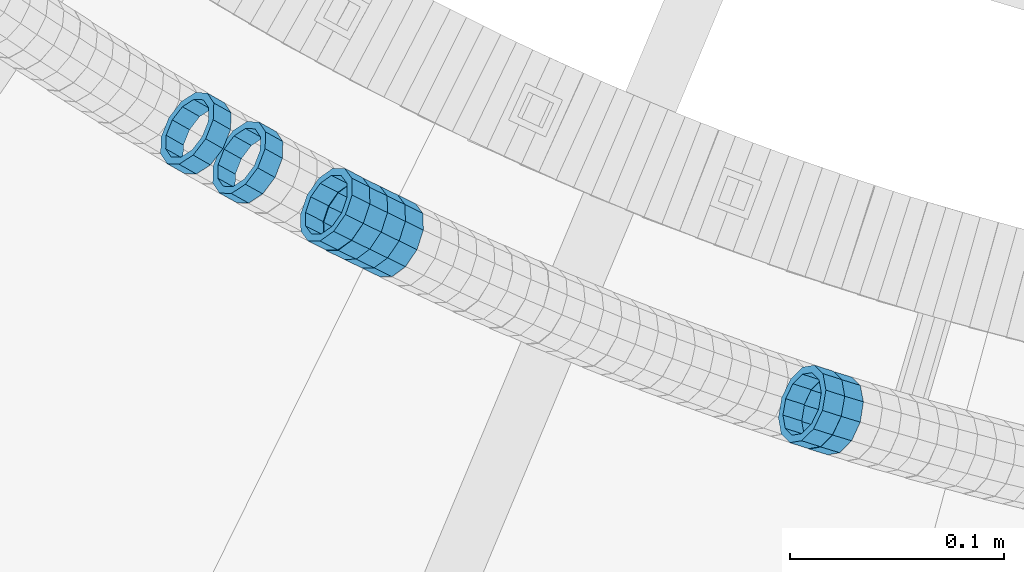
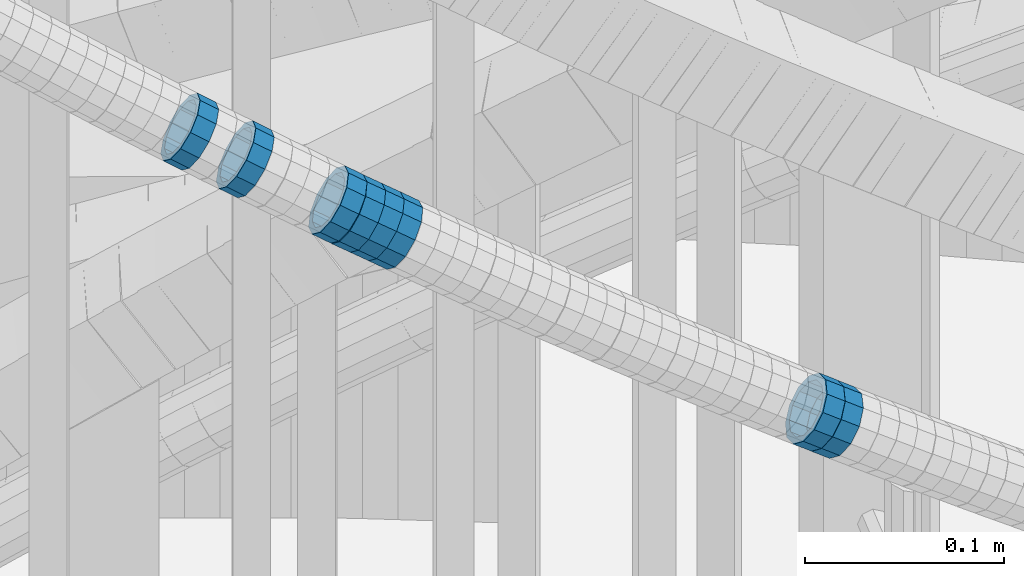
# One storey, part 692 of 975: 8 members.
"""IFC2X3 building model written with IfcOpenShell, lengths in millimetres."""

from ifc_helpers import new_model, si_unit, frame, origin_with_axes, place, context, subcontext, project, spatial, faceted_brep, material, type_object, element, save


model = new_model("IFC2X3")

# Units and contexts
model_context = context("Model", 3, precision=1e-05, world=origin_with_axes())
body_context = subcontext(model_context, "Body", "Model", "MODEL_VIEW")
ifc_project = project(units=[si_unit("LENGTHUNIT", "METRE", prefix="MILLI"), si_unit("AREAUNIT", "SQUARE_METRE"), si_unit("VOLUMEUNIT", "CUBIC_METRE"), si_unit("MASSUNIT", "GRAM", prefix="KILO"), si_unit("TIMEUNIT", "SECOND"), si_unit("PLANEANGLEUNIT", "RADIAN"), si_unit("SOLIDANGLEUNIT", "STERADIAN"), si_unit("THERMODYNAMICTEMPERATUREUNIT", "DEGREE_CELSIUS"), si_unit("LUMINOUSINTENSITYUNIT", "LUMEN")], contexts=[model_context])

# Site, building, storey
site_placement = place(None, origin_with_axes())
site = spatial("IfcSite", under=ifc_project, at=site_placement, CompositionType="ELEMENT")
building_placement = place(site_placement, origin_with_axes())
building = spatial("IfcBuilding", under=site, at=building_placement, Name="Undefined", CompositionType="ELEMENT")
storey_placement = place(building_placement, origin_with_axes())
storey = spatial("IfcBuildingStorey", under=building, at=storey_placement, Name="Undefined", CompositionType="ELEMENT", Elevation=0.0)

# Members
ifc_material = material()
member_type = type_object("IfcMemberType", PredefinedType="NOTDEFINED")
member_1_placement = place(storey_placement, frame((34293.7503061323, 1991.13379938995, 4482.93561378723), z_axis=(-0.290305798469577, -0.95693392842711, -3.87069121643435e-10), x_axis=(-0.811981609245626, 0.246331499074519, 0.529156554160093)))
element("IfcMember", 1, at=member_1_placement, inside=storey, type_object=member_type, material=ifc_material, Name="WALL", context=body_context, shape_type="Brep", body=[
    faceted_brep([(-2.1246523829177e-07, -15.367000000002, 0.0), (-1.83998054126278e-07, -13.3082123799541, 7.68350000000009), (10.9608393839299, -13.3082123799613, 7.68350000000282), (10.9608393839189, -15.3670000000093, 3.63797880709171e-12), (-1.06232619145885e-07, -7.68349999999919, 13.3082123799559), (10.9608393839408, -7.68349999999919, 13.3082123799563), (-3.63797880709171e-12, 3.63797880709171e-12, 15.3670000000002), (10.9608393839517, 3.63797880709171e-12, 15.3669999999993), (1.06225343188271e-07, 7.68350000000646, 13.3082123799559), (10.960839383959, 7.68350000000282, 13.3082123799536), (1.8399441614747e-07, 13.308212379965, 7.68350000000009), (10.9608393839553, 13.3082123799577, 7.68349999999782), (2.12461600312963e-07, 15.3670000000093, 0.0), (10.960839383959, 15.367000000002, -2.27373675443232e-12), (1.8399441614747e-07, 13.308212379965, -7.68350000000009), (10.960839383948, 13.3082123799468, -7.68350000000146), (1.06225343188271e-07, 7.68350000000646, -13.3082123799559), (10.9608393839408, 7.68349999998827, -13.3082123799563), (-3.63797880709171e-12, 3.63797880709171e-12, -15.3670000000002), (10.9608393839299, -1.09139364212751e-11, -15.3669999999993), (-1.06232619145885e-07, -7.68349999999919, -13.3082123799559), (10.9608393839226, -7.68350000001374, -13.3082123799531), (-1.83998054126278e-07, -13.3082123799541, -7.68350000000009), (10.9608393839226, -13.308212379965, -7.68349999999691), (-2.63386027654633e-07, -19.0500000000029, 0.0), (-2.28097633225843e-07, -16.4977839420972, -9.52499999999964), (10.9608393839153, -16.4977839421081, -9.52499999999645), (10.9608393839153, -19.0500000000065, 4.09272615797818e-12), (-1.31691194837913e-07, -9.52500000000146, -16.4977839420935), (10.9608393839189, -9.52500000001237, -16.4977839420908), (-3.63797880709171e-12, 3.63797880709171e-12, -19.0500000000002), (10.9608393839262, -1.45519152283669e-11, -19.0499999999984), (1.31687556859106e-07, 9.52500000000509, -16.4977839420935), (10.9608393839371, 9.5249999999869, -16.4977839420935), (2.28097633225843e-07, 16.4977839421044, -9.52499999999964), (10.9608393839553, 16.4977839420899, -9.52500000000282), (2.63382389675826e-07, 19.0500000000138, 0.0), (10.9608393839626, 19.0499999999993, -3.18323145620525e-12), (2.28097633225843e-07, 16.4977839421044, 9.52499999999964), (10.9608393839626, 16.4977839420972, 9.52499999999645), (1.31687556859106e-07, 9.52500000000509, 16.4977839420935), (10.960839383959, 9.52500000000509, 16.4977839420917), (-3.63797880709171e-12, 3.63797880709171e-12, 19.0500000000002), (10.9608393839517, 7.27595761418343e-12, 19.0499999999997), (-1.31691194837913e-07, -9.52500000000146, 16.4977839420935), (10.9608393839408, -9.52499999999782, 16.4977839420944), (-2.28097633225843e-07, -16.4977839420972, 9.52499999999964), (10.9608393839226, -16.4977839420972, 9.52500000000418)], [[[0, 1, 2, 3]], [[1, 4, 5, 2]], [[4, 6, 7, 5]], [[6, 8, 9, 7]], [[8, 10, 11, 9]], [[10, 12, 13, 11]], [[12, 14, 15, 13]], [[14, 16, 17, 15]], [[16, 18, 19, 17]], [[18, 20, 21, 19]], [[20, 22, 23, 21]], [[22, 0, 3, 23]], [[24, 25, 26, 27]], [[25, 28, 29, 26]], [[28, 30, 31, 29]], [[30, 32, 33, 31]], [[32, 34, 35, 33]], [[34, 36, 37, 35]], [[36, 38, 39, 37]], [[38, 40, 41, 39]], [[40, 42, 43, 41]], [[42, 44, 45, 43]], [[44, 46, 47, 45]], [[46, 24, 27, 47]], [[29, 31, 33, 35, 37, 39, 41, 43, 45, 47, 27, 26], [5, 7, 9, 11, 13, 15, 17, 19, 21, 23, 3, 2]], [[46, 44, 42, 40, 38, 36, 34, 32, 30, 28, 25, 24], [22, 20, 18, 16, 14, 12, 10, 8, 6, 4, 1, 0]]]),
])
member_2_placement = place(storey_placement, frame((34284.961814162, 1993.94119133167, 4488.68931985293), z_axis=(-0.303203656716891, -0.952925780191462, -2.02349838218652e-10), x_axis=(-0.810896329800662, 0.258012467936574, 0.525239667870863)))
element("IfcMember", 2, at=member_2_placement, inside=storey, type_object=member_type, material=ifc_material, Name="WALL", context=body_context, shape_type="Brep", body=[
    faceted_brep([(-2.1246523829177e-07, -15.367000000002, 0.0), (-1.83998054126278e-07, -13.3082123799541, 7.68350000000009), (10.8531101533481, -13.3082123799322, 7.68350000001374), (10.8531101533372, -15.3669999999838, 9.09494701772928e-12), (-1.06232619145885e-07, -7.68349999999919, 13.3082123799559), (10.8531101533517, -7.68349999997736, 13.3082123799686), (-3.63797880709171e-12, 3.63797880709171e-12, 15.3670000000002), (10.8531101533481, 1.45519152283669e-11, 15.3670000000129), (1.06225343188271e-07, 7.68350000000646, 13.3082123799559), (10.8531101533335, 7.68350000000282, 13.3082123799595), (1.8399441614747e-07, 13.308212379965, 7.68350000000009), (10.8531101533117, 13.3082123799468, 7.68349999999373), (2.12461600312963e-07, 15.3670000000093, 0.0), (10.8531101532935, 15.3669999999838, -1.2732925824821e-11), (1.8399441614747e-07, 13.308212379965, -7.68350000000009), (10.853110153279, 13.3082123799322, -7.68350000001737), (1.06225343188271e-07, 7.68350000000646, -13.3082123799559), (10.8531101532717, 7.68349999997736, -13.3082123799741), (-3.63797880709171e-12, 3.63797880709171e-12, -15.3670000000002), (10.853110153279, -1.45519152283669e-11, -15.3670000000166), (-1.06232619145885e-07, -7.68349999999919, -13.3082123799559), (10.8531101532972, -7.68349999999919, -13.3082123799632), (-1.83998054126278e-07, -13.3082123799541, -7.68350000000009), (10.8531101533154, -13.3082123799504, -7.68349999999919), (-2.63386027654633e-07, -19.0500000000029, 0.0), (-2.28097633225843e-07, -16.4977839420972, -9.52499999999964), (10.8531101533154, -16.4977839420826, -9.52499999999782), (10.8531101533408, -19.0499999999774, 1.09139364212751e-11), (-1.31691194837913e-07, -9.52500000000146, -16.4977839420935), (10.8531101532935, -9.52500000000509, -16.4977839421044), (-3.63797880709171e-12, 3.63797880709171e-12, -19.0500000000002), (10.8531101532717, -1.81898940354586e-11, -19.0500000000193), (1.31687556859106e-07, 9.52500000000509, -16.4977839420935), (10.8531101532681, 9.52499999997599, -16.4977839421172), (2.28097633225843e-07, 16.4977839421044, -9.52499999999964), (10.8531101532717, 16.4977839420681, -9.52500000002328), (2.63382389675826e-07, 19.0500000000138, 0.0), (10.8531101532899, 19.0499999999811, -1.63709046319127e-11), (2.28097633225843e-07, 16.4977839421044, 9.52499999999964), (10.8531101533117, 16.4977839420862, 9.52499999999236), (1.31687556859106e-07, 9.52500000000509, 16.4977839420935), (10.8531101533372, 9.52500000000509, 16.497783942099), (-3.63797880709171e-12, 3.63797880709171e-12, 19.0500000000002), (10.853110153359, 1.81898940354586e-11, 19.0500000000156), (-1.31691194837913e-07, -9.52500000000146, 16.4977839420935), (10.853110153359, -9.52499999997963, 16.4977839421099), (-2.28097633225843e-07, -16.4977839420972, 9.52499999999964), (10.853110153359, -16.4977839420681, 9.52500000001783)], [[[0, 1, 2, 3]], [[1, 4, 5, 2]], [[4, 6, 7, 5]], [[6, 8, 9, 7]], [[8, 10, 11, 9]], [[10, 12, 13, 11]], [[12, 14, 15, 13]], [[14, 16, 17, 15]], [[16, 18, 19, 17]], [[18, 20, 21, 19]], [[20, 22, 23, 21]], [[22, 0, 3, 23]], [[24, 25, 26, 27]], [[25, 28, 29, 26]], [[28, 30, 31, 29]], [[30, 32, 33, 31]], [[32, 34, 35, 33]], [[34, 36, 37, 35]], [[36, 38, 39, 37]], [[38, 40, 41, 39]], [[40, 42, 43, 41]], [[42, 44, 45, 43]], [[44, 46, 47, 45]], [[46, 24, 27, 47]], [[29, 31, 33, 35, 37, 39, 41, 43, 45, 47, 27, 26], [5, 7, 9, 11, 13, 15, 17, 19, 21, 23, 3, 2]], [[46, 44, 42, 40, 38, 36, 34, 32, 30, 28, 25, 24], [22, 20, 18, 16, 14, 12, 10, 8, 6, 4, 1, 0]]]),
])
member_3_placement = place(storey_placement, frame((34020.5714160654, 2107.65472353769, 4666.47419361591), z_axis=(-0.485642930938862, -0.874157276254743, -1.10892869997769e-10), x_axis=(-0.744562034998784, 0.413645574999246, 0.523951060999033)))
element("IfcMember", 3, at=member_3_placement, inside=storey, type_object=member_type, material=ifc_material, Name="WALL", context=body_context, shape_type="Brep", body=[
    faceted_brep([(-2.1246523829177e-07, -15.367000000002, 0.0), (-1.83998054126278e-07, -13.3082123799541, 7.68350000000009), (10.8784190028109, -13.3082123799541, 7.68349999999555), (10.8784190028309, -15.3669999999929, 2.5465851649642e-11), (-1.06232619145885e-07, -7.68349999999919, 13.3082123799559), (10.8784190027873, -7.68350000000464, 13.308212379925), (-3.63797880709171e-12, 3.63797880709171e-12, 15.3670000000002), (10.8784190027782, -9.09494701772928e-12, 15.3669999999584), (1.06225343188271e-07, 7.68350000000646, 13.3082123799559), (10.8784190027691, 7.68349999998645, 13.3082123798995), (1.8399441614747e-07, 13.308212379965, 7.68350000000009), (10.8784190027764, 13.3082123799431, 7.68349999995553), (2.12461600312963e-07, 15.3670000000093, 0.0), (10.8784190027891, 15.3669999999929, -2.91038304567337e-11), (1.8399441614747e-07, 13.308212379965, -7.68350000000009), (10.8784190028055, 13.3082123799541, -7.68350000000646), (1.06225343188271e-07, 7.68350000000646, -13.3082123799559), (10.8784190028236, 7.68350000000464, -13.3082123799431), (-3.63797880709171e-12, 3.63797880709171e-12, -15.3670000000002), (10.87841900284, 1.2732925824821e-11, -15.366999999962), (-1.06232619145885e-07, -7.68349999999919, -13.3082123799559), (10.8784190028437, -7.68349999998463, -13.308212379914), (-1.83998054126278e-07, -13.3082123799541, -7.68350000000009), (10.8784190028437, -13.3082123799413, -7.68349999996281), (-2.63386027654633e-07, -19.0500000000029, 0.0), (-2.28097633225843e-07, -16.4977839420972, -9.52499999999964), (10.8784190028491, -16.4977839420771, -9.52499999995416), (10.8784190028346, -19.0499999999902, 2.91038304567337e-11), (-1.31691194837913e-07, -9.52500000000146, -16.4977839420935), (10.8784190028582, -9.52499999998145, -16.497783942039), (-3.63797880709171e-12, 3.63797880709171e-12, -19.0500000000002), (10.8784190028473, 1.63709046319127e-11, -19.0499999999556), (1.31687556859106e-07, 9.52500000000509, -16.4977839420935), (10.8784190028291, 9.52500000000691, -16.4977839420753), (2.28097633225843e-07, 16.4977839421044, -9.52499999999964), (10.8784190028073, 16.4977839420917, -9.52500000000509), (2.63382389675826e-07, 19.0500000000138, 0.0), (10.8784190027836, 19.0499999999884, -4.00177668780088e-11), (2.28097633225843e-07, 16.4977839421044, 9.52499999999964), (10.8784190027654, 16.4977839420771, 9.52499999994325), (1.31687556859106e-07, 9.52500000000509, 16.4977839420935), (10.8784190027636, 9.52499999998327, 16.4977839420317), (-3.63797880709171e-12, 3.63797880709171e-12, 19.0500000000002), (10.8784190027709, -1.63709046319127e-11, 19.0499999999447), (-1.31691194837913e-07, -9.52500000000146, 16.4977839420935), (10.8784190027854, -9.52500000000691, 16.4977839420644), (-2.28097633225843e-07, -16.4977839420972, 9.52499999999964), (10.8784190028091, -16.4977839420899, 9.52500000000146)], [[[0, 1, 2, 3]], [[1, 4, 5, 2]], [[4, 6, 7, 5]], [[6, 8, 9, 7]], [[8, 10, 11, 9]], [[10, 12, 13, 11]], [[12, 14, 15, 13]], [[14, 16, 17, 15]], [[16, 18, 19, 17]], [[18, 20, 21, 19]], [[20, 22, 23, 21]], [[22, 0, 3, 23]], [[24, 25, 26, 27]], [[25, 28, 29, 26]], [[28, 30, 31, 29]], [[30, 32, 33, 31]], [[32, 34, 35, 33]], [[34, 36, 37, 35]], [[36, 38, 39, 37]], [[38, 40, 41, 39]], [[40, 42, 43, 41]], [[42, 44, 45, 43]], [[44, 46, 47, 45]], [[46, 24, 27, 47]], [[29, 31, 33, 35, 37, 39, 41, 43, 45, 47, 27, 26], [5, 7, 9, 11, 13, 15, 17, 19, 21, 23, 3, 2]], [[46, 44, 42, 40, 38, 36, 34, 32, 30, 28, 25, 24], [22, 20, 18, 16, 14, 12, 10, 8, 6, 4, 1, 0]]]),
])
member_4_placement = place(storey_placement, frame((34086.7702993704, 2073.41309254897, 4620.51303171297), z_axis=(-0.438634400976589, -0.898665600921672, 8.26184987090528e-12), x_axis=(-0.763604810337577, 0.372711872164798, 0.527250940233135)))
element("IfcMember", 4, at=member_4_placement, inside=storey, type_object=member_type, material=ifc_material, Name="WALL", context=body_context, shape_type="Brep", body=[
    faceted_brep([(-2.1246523829177e-07, -15.367000000002, 0.0), (-1.83998054126278e-07, -13.3082123799541, 7.68350000000009), (11.0022724925184, -13.3082123799686, 7.6835000000101), (11.0022724925111, -15.3670000000129, 1.45519152283669e-11), (-1.06232619145885e-07, -7.68349999999919, 13.3082123799559), (11.002272492522, -7.6835000000101, 13.308212379965), (-3.63797880709171e-12, 3.63797880709171e-12, 15.3670000000002), (11.0022724925257, -7.27595761418343e-12, 15.3670000000056), (1.06225343188271e-07, 7.68350000000646, 13.3082123799559), (11.0022724925329, 7.68349999999919, 13.3082123799559), (1.8399441614747e-07, 13.308212379965, 7.68350000000009), (11.0022724925329, 13.3082123799577, 7.68349999999919), (2.12461600312963e-07, 15.3670000000093, 0.0), (11.0022724925366, 15.367000000002, -3.63797880709171e-12), (1.8399441614747e-07, 13.308212379965, -7.68350000000009), (11.0022724925329, 13.3082123799577, -7.68350000000464), (1.06225343188271e-07, 7.68350000000646, -13.3082123799559), (11.0022724925366, 7.68350000000282, -13.3082123799577), (-3.63797880709171e-12, 3.63797880709171e-12, -15.3670000000002), (11.0022724925257, -3.63797880709171e-12, -15.3669999999984), (-1.06232619145885e-07, -7.68349999999919, -13.3082123799559), (11.002272492522, -7.68350000000646, -13.3082123799486), (-1.83998054126278e-07, -13.3082123799541, -7.68350000000009), (11.0022724925184, -13.308212379965, -7.68349999999009), (-2.63386027654633e-07, -19.0500000000029, 0.0), (-2.28097633225843e-07, -16.4977839420972, -9.52499999999964), (11.0022724925147, -16.4977839421044, -9.5249999999869), (11.0022724925111, -19.0500000000138, 1.45519152283669e-11), (-1.31691194837913e-07, -9.52500000000146, -16.4977839420935), (11.0022724925184, -9.52500000000873, -16.4977839420881), (-3.63797880709171e-12, 3.63797880709171e-12, -19.0500000000002), (11.0022724925257, -7.27595761418343e-12, -19.0499999999975), (1.31687556859106e-07, 9.52500000000509, -16.4977839420935), (11.0022724925329, 9.52500000000146, -16.4977839420953), (2.28097633225843e-07, 16.4977839421044, -9.52499999999964), (11.0022724925329, 16.4977839420935, -9.52500000000509), (2.63382389675826e-07, 19.0500000000138, 0.0), (11.0022724925366, 19.0500000000029, -5.45696821063757e-12), (2.28097633225843e-07, 16.4977839421044, 9.52499999999964), (11.0022724925366, 16.4977839420972, 9.524999999996), (1.31687556859106e-07, 9.52500000000509, 16.4977839420935), (11.0022724925329, 9.52499999999418, 16.4977839420953), (-3.63797880709171e-12, 3.63797880709171e-12, 19.0500000000002), (11.0022724925293, -3.63797880709171e-12, 19.0500000000047), (-1.31691194837913e-07, -9.52500000000146, 16.4977839420935), (11.002272492522, -9.52500000000873, 16.4977839421026), (-2.28097633225843e-07, -16.4977839420972, 9.52499999999964), (11.0022724925147, -16.4977839421081, 9.52500000001237)], [[[0, 1, 2, 3]], [[1, 4, 5, 2]], [[4, 6, 7, 5]], [[6, 8, 9, 7]], [[8, 10, 11, 9]], [[10, 12, 13, 11]], [[12, 14, 15, 13]], [[14, 16, 17, 15]], [[16, 18, 19, 17]], [[18, 20, 21, 19]], [[20, 22, 23, 21]], [[22, 0, 3, 23]], [[24, 25, 26, 27]], [[25, 28, 29, 26]], [[28, 30, 31, 29]], [[30, 32, 33, 31]], [[32, 34, 35, 33]], [[34, 36, 37, 35]], [[36, 38, 39, 37]], [[38, 40, 41, 39]], [[40, 42, 43, 41]], [[42, 44, 45, 43]], [[44, 46, 47, 45]], [[46, 24, 27, 47]], [[29, 31, 33, 35, 37, 39, 41, 43, 45, 47, 27, 26], [5, 7, 9, 11, 13, 15, 17, 19, 21, 23, 3, 2]], [[46, 44, 42, 40, 38, 36, 34, 32, 30, 28, 25, 24], [22, 20, 18, 16, 14, 12, 10, 8, 6, 4, 1, 0]]]),
])
member_5_placement = place(storey_placement, frame((34078.4834720402, 2077.45785350777, 4626.23556393409), z_axis=(-0.438634400976589, -0.898665600921672, 8.26184987090528e-12), x_axis=(-0.767259279184494, 0.374495600090076, 0.520640225125244)))
element("IfcMember", 5, at=member_5_placement, inside=storey, type_object=member_type, material=ifc_material, Name="WALL", context=body_context, shape_type="Brep", body=[
    faceted_brep([(-2.1246523829177e-07, -15.367000000002, 0.0), (-1.83998054126278e-07, -13.3082123799541, 7.68350000000009), (10.9530817580962, -13.3082123799686, 7.68350000001737), (10.9530817580853, -15.3670000000202, 2.5465851649642e-11), (-1.06232619145885e-07, -7.68349999999919, 13.3082123799559), (10.9530817581108, -7.6835000000101, 13.308212379965), (-3.63797880709171e-12, 3.63797880709171e-12, 15.3670000000002), (10.9530817581144, -3.63797880709171e-12, 15.367000000002), (1.06225343188271e-07, 7.68350000000646, 13.3082123799559), (10.9530817581326, 7.68350000000646, 13.3082123799504), (1.8399441614747e-07, 13.308212379965, 7.68350000000009), (10.9530817581362, 13.308212379965, 7.68349999999191), (2.12461600312963e-07, 15.3670000000093, 0.0), (10.9530817581399, 15.3670000000056, -1.09139364212751e-11), (1.8399441614747e-07, 13.308212379965, -7.68350000000009), (10.9530817581362, 13.3082123799613, -7.68350000000282), (1.06225343188271e-07, 7.68350000000646, -13.3082123799559), (10.9530817581217, 7.68349999999919, -13.3082123799504), (-3.63797880709171e-12, 3.63797880709171e-12, -15.3670000000002), (10.9530817581108, -7.27595761418343e-12, -15.3669999999875), (-1.06232619145885e-07, -7.68349999999919, -13.3082123799559), (10.9530817580999, -7.68350000001374, -13.3082123799359), (-1.83998054126278e-07, -13.3082123799541, -7.68350000000009), (10.9530817580926, -13.3082123799722, -7.68349999997372), (-2.63386027654633e-07, -19.0500000000029, 0.0), (-2.28097633225843e-07, -16.4977839420972, -9.52499999999964), (10.9530817580853, -16.4977839421117, -9.52499999996871), (10.953081758078, -19.0500000000211, 2.91038304567337e-11), (-1.31691194837913e-07, -9.52500000000146, -16.4977839420935), (10.9530817580926, -9.52500000001601, -16.4977839420681), (-3.63797880709171e-12, 3.63797880709171e-12, -19.0500000000002), (10.9530817581071, -7.27595761418343e-12, -19.0499999999884), (1.31687556859106e-07, 9.52500000000509, -16.4977839420935), (10.953081758129, 9.52500000000146, -16.4977839420935), (2.28097633225843e-07, 16.4977839421044, -9.52499999999964), (10.9530817581399, 16.4977839421008, -9.52500000000509), (2.63382389675826e-07, 19.0500000000138, 0.0), (10.9530817581435, 19.0500000000102, -1.09139364212751e-11), (2.28097633225843e-07, 16.4977839421044, 9.52499999999964), (10.9530817581472, 16.4977839421044, 9.5249999999869), (1.31687556859106e-07, 9.52500000000509, 16.4977839420935), (10.9530817581362, 9.52500000000509, 16.4977839420826), (-3.63797880709171e-12, 3.63797880709171e-12, 19.0500000000002), (10.9530817581217, -3.63797880709171e-12, 19.0499999999993), (-1.31691194837913e-07, -9.52500000000146, 16.4977839420935), (10.9530817581035, -9.52500000001237, 16.4977839421081), (-2.28097633225843e-07, -16.4977839420972, 9.52499999999964), (10.953081758089, -16.4977839421081, 9.52500000002328)], [[[0, 1, 2, 3]], [[1, 4, 5, 2]], [[4, 6, 7, 5]], [[6, 8, 9, 7]], [[8, 10, 11, 9]], [[10, 12, 13, 11]], [[12, 14, 15, 13]], [[14, 16, 17, 15]], [[16, 18, 19, 17]], [[18, 20, 21, 19]], [[20, 22, 23, 21]], [[22, 0, 3, 23]], [[24, 25, 26, 27]], [[25, 28, 29, 26]], [[28, 30, 31, 29]], [[30, 32, 33, 31]], [[32, 34, 35, 33]], [[34, 36, 37, 35]], [[36, 38, 39, 37]], [[38, 40, 41, 39]], [[40, 42, 43, 41]], [[42, 44, 45, 43]], [[44, 46, 47, 45]], [[46, 24, 27, 47]], [[29, 31, 33, 35, 37, 39, 41, 43, 45, 47, 27, 26], [5, 7, 9, 11, 13, 15, 17, 19, 21, 23, 3, 2]], [[46, 44, 42, 40, 38, 36, 34, 32, 30, 28, 25, 24], [22, 20, 18, 16, 14, 12, 10, 8, 6, 4, 1, 0]]]),
])
member_6_placement = place(storey_placement, frame((34070.0834720401, 2081.55785350777, 4631.93556393411), z_axis=(-0.438634400976589, -0.898665600921672, 8.26184987090528e-12), x_axis=(-0.767259279184494, 0.374495600090076, 0.520640225125244)))
element("IfcMember", 6, at=member_6_placement, inside=storey, type_object=member_type, material=ifc_material, Name="WALL", context=body_context, shape_type="Brep", body=[
    faceted_brep([(-2.1246523829177e-07, -15.367000000002, 0.0), (-1.83998054126278e-07, -13.3082123799541, 7.68350000000009), (10.9530817580962, -13.3082123799686, 7.68350000001737), (10.9530817580853, -15.3670000000202, 2.5465851649642e-11), (-1.06232619145885e-07, -7.68349999999919, 13.3082123799559), (10.9530817581108, -7.6835000000101, 13.308212379965), (-3.63797880709171e-12, 3.63797880709171e-12, 15.3670000000002), (10.9530817581144, -3.63797880709171e-12, 15.367000000002), (1.06225343188271e-07, 7.68350000000646, 13.3082123799559), (10.9530817581326, 7.68350000000646, 13.3082123799504), (1.8399441614747e-07, 13.308212379965, 7.68350000000009), (10.9530817581362, 13.308212379965, 7.68349999999191), (2.12461600312963e-07, 15.3670000000093, 0.0), (10.9530817581399, 15.3670000000056, -1.09139364212751e-11), (1.8399441614747e-07, 13.308212379965, -7.68350000000009), (10.9530817581362, 13.3082123799613, -7.68350000000282), (1.06225343188271e-07, 7.68350000000646, -13.3082123799559), (10.9530817581217, 7.68349999999919, -13.3082123799504), (-3.63797880709171e-12, 3.63797880709171e-12, -15.3670000000002), (10.9530817581108, -7.27595761418343e-12, -15.3669999999875), (-1.06232619145885e-07, -7.68349999999919, -13.3082123799559), (10.9530817580999, -7.68350000001374, -13.3082123799359), (-1.83998054126278e-07, -13.3082123799541, -7.68350000000009), (10.9530817580926, -13.3082123799722, -7.68349999997372), (-2.63386027654633e-07, -19.0500000000029, 0.0), (-2.28097633225843e-07, -16.4977839420972, -9.52499999999964), (10.9530817580853, -16.4977839421117, -9.52499999996871), (10.953081758078, -19.0500000000211, 2.91038304567337e-11), (-1.31691194837913e-07, -9.52500000000146, -16.4977839420935), (10.9530817580926, -9.52500000001601, -16.4977839420681), (-3.63797880709171e-12, 3.63797880709171e-12, -19.0500000000002), (10.9530817581071, -7.27595761418343e-12, -19.0499999999884), (1.31687556859106e-07, 9.52500000000509, -16.4977839420935), (10.953081758129, 9.52500000000146, -16.4977839420935), (2.28097633225843e-07, 16.4977839421044, -9.52499999999964), (10.9530817581399, 16.4977839421008, -9.52500000000509), (2.63382389675826e-07, 19.0500000000138, 0.0), (10.9530817581435, 19.0500000000102, -1.09139364212751e-11), (2.28097633225843e-07, 16.4977839421044, 9.52499999999964), (10.9530817581472, 16.4977839421044, 9.5249999999869), (1.31687556859106e-07, 9.52500000000509, 16.4977839420935), (10.9530817581362, 9.52500000000509, 16.4977839420826), (-3.63797880709171e-12, 3.63797880709171e-12, 19.0500000000002), (10.9530817581217, -3.63797880709171e-12, 19.0499999999993), (-1.31691194837913e-07, -9.52500000000146, 16.4977839420935), (10.9530817581035, -9.52500000001237, 16.4977839421081), (-2.28097633225843e-07, -16.4977839420972, 9.52499999999964), (10.953081758089, -16.4977839421081, 9.52500000002328)], [[[0, 1, 2, 3]], [[1, 4, 5, 2]], [[4, 6, 7, 5]], [[6, 8, 9, 7]], [[8, 10, 11, 9]], [[10, 12, 13, 11]], [[12, 14, 15, 13]], [[14, 16, 17, 15]], [[16, 18, 19, 17]], [[18, 20, 21, 19]], [[20, 22, 23, 21]], [[22, 0, 3, 23]], [[24, 25, 26, 27]], [[25, 28, 29, 26]], [[28, 30, 31, 29]], [[30, 32, 33, 31]], [[32, 34, 35, 33]], [[34, 36, 37, 35]], [[36, 38, 39, 37]], [[38, 40, 41, 39]], [[40, 42, 43, 41]], [[42, 44, 45, 43]], [[44, 46, 47, 45]], [[46, 24, 27, 47]], [[29, 31, 33, 35, 37, 39, 41, 43, 45, 47, 27, 26], [5, 7, 9, 11, 13, 15, 17, 19, 21, 23, 3, 2]], [[46, 44, 42, 40, 38, 36, 34, 32, 30, 28, 25, 24], [22, 20, 18, 16, 14, 12, 10, 8, 6, 4, 1, 0]]]),
])
member_7_placement = place(storey_placement, frame((34061.6033013906, 2085.858224245, 4637.73482912375), z_axis=(-0.451508507795502, -0.892266814012647, -1.17328454507515e-10), x_axis=(-0.757146749008516, 0.383134499004386, 0.529090499006071)))
element("IfcMember", 7, at=member_7_placement, inside=storey, type_object=member_type, material=ifc_material, Name="WALL", context=body_context, shape_type="Brep", body=[
    faceted_brep([(-2.1246523829177e-07, -15.367000000002, 0.0), (-1.83998054126278e-07, -13.3082123799541, 7.68350000000009), (10.9608393839299, -13.3082123799613, 7.68350000000282), (10.9608393839189, -15.3670000000093, 3.63797880709171e-12), (-1.06232619145885e-07, -7.68349999999919, 13.3082123799559), (10.9608393839408, -7.68349999999919, 13.3082123799563), (-3.63797880709171e-12, 3.63797880709171e-12, 15.3670000000002), (10.9608393839517, 3.63797880709171e-12, 15.3669999999993), (1.06225343188271e-07, 7.68350000000646, 13.3082123799559), (10.960839383959, 7.68350000000282, 13.3082123799536), (1.8399441614747e-07, 13.308212379965, 7.68350000000009), (10.9608393839553, 13.3082123799577, 7.68349999999782), (2.12461600312963e-07, 15.3670000000093, 0.0), (10.960839383959, 15.367000000002, -2.27373675443232e-12), (1.8399441614747e-07, 13.308212379965, -7.68350000000009), (10.960839383948, 13.3082123799468, -7.68350000000146), (1.06225343188271e-07, 7.68350000000646, -13.3082123799559), (10.9608393839408, 7.68349999998827, -13.3082123799563), (-3.63797880709171e-12, 3.63797880709171e-12, -15.3670000000002), (10.9608393839299, -1.09139364212751e-11, -15.3669999999993), (-1.06232619145885e-07, -7.68349999999919, -13.3082123799559), (10.9608393839226, -7.68350000001374, -13.3082123799531), (-1.83998054126278e-07, -13.3082123799541, -7.68350000000009), (10.9608393839226, -13.308212379965, -7.68349999999691), (-2.63386027654633e-07, -19.0500000000029, 0.0), (-2.28097633225843e-07, -16.4977839420972, -9.52499999999964), (10.9608393839153, -16.4977839421081, -9.52499999999645), (10.9608393839153, -19.0500000000065, 4.09272615797818e-12), (-1.31691194837913e-07, -9.52500000000146, -16.4977839420935), (10.9608393839189, -9.52500000001237, -16.4977839420908), (-3.63797880709171e-12, 3.63797880709171e-12, -19.0500000000002), (10.9608393839262, -1.45519152283669e-11, -19.0499999999984), (1.31687556859106e-07, 9.52500000000509, -16.4977839420935), (10.9608393839371, 9.5249999999869, -16.4977839420935), (2.28097633225843e-07, 16.4977839421044, -9.52499999999964), (10.9608393839553, 16.4977839420899, -9.52500000000282), (2.63382389675826e-07, 19.0500000000138, 0.0), (10.9608393839626, 19.0499999999993, -3.18323145620525e-12), (2.28097633225843e-07, 16.4977839421044, 9.52499999999964), (10.9608393839626, 16.4977839420972, 9.52499999999645), (1.31687556859106e-07, 9.52500000000509, 16.4977839420935), (10.960839383959, 9.52500000000509, 16.4977839420917), (-3.63797880709171e-12, 3.63797880709171e-12, 19.0500000000002), (10.9608393839517, 7.27595761418343e-12, 19.0499999999997), (-1.31691194837913e-07, -9.52500000000146, 16.4977839420935), (10.9608393839408, -9.52499999999782, 16.4977839420944), (-2.28097633225843e-07, -16.4977839420972, 9.52499999999964), (10.9608393839226, -16.4977839420972, 9.52500000000418)], [[[0, 1, 2, 3]], [[1, 4, 5, 2]], [[4, 6, 7, 5]], [[6, 8, 9, 7]], [[8, 10, 11, 9]], [[10, 12, 13, 11]], [[12, 14, 15, 13]], [[14, 16, 17, 15]], [[16, 18, 19, 17]], [[18, 20, 21, 19]], [[20, 22, 23, 21]], [[22, 0, 3, 23]], [[24, 25, 26, 27]], [[25, 28, 29, 26]], [[28, 30, 31, 29]], [[30, 32, 33, 31]], [[32, 34, 35, 33]], [[34, 36, 37, 35]], [[36, 38, 39, 37]], [[38, 40, 41, 39]], [[40, 42, 43, 41]], [[42, 44, 45, 43]], [[44, 46, 47, 45]], [[46, 24, 27, 47]], [[29, 31, 33, 35, 37, 39, 41, 43, 45, 47, 27, 26], [5, 7, 9, 11, 13, 15, 17, 19, 21, 23, 3, 2]], [[46, 44, 42, 40, 38, 36, 34, 32, 30, 28, 25, 24], [22, 20, 18, 16, 14, 12, 10, 8, 6, 4, 1, 0]]]),
])
member_8_placement = place(storey_placement, frame((33996.2504661066, 2121.21754941307, 4683.65078538714), z_axis=(-0.493824955118245, -0.869561334065897, 4.30081854574382e-11), x_axis=(-0.741715946773775, 0.421221401871507, 0.521948258840746)))
element("IfcMember", 8, at=member_8_placement, inside=storey, type_object=member_type, material=ifc_material, Name="WALL", context=body_context, shape_type="Brep", body=[
    faceted_brep([(-2.1246523829177e-07, -15.367000000002, 0.0), (-1.83998054126278e-07, -13.3082123799541, 7.68350000000009), (10.9242848735521, -13.3082123800159, 7.68350000000919), (10.9242848735703, -15.3670000000457, 6.82121026329696e-12), (-1.06232619145885e-07, -7.68349999999919, 13.3082123799559), (10.9242848735521, -7.68350000005739, 13.3082123799652), (-3.63797880709171e-12, 3.63797880709171e-12, 15.3670000000002), (10.924284873563, -4.72937244921923e-11, 15.3670000000088), (1.06225343188271e-07, 7.68350000000646, 13.3082123799559), (10.9242848735885, 7.68349999997008, 13.308212379962), (1.8399441614747e-07, 13.308212379965, 7.68350000000009), (10.9242848736176, 13.3082123799468, 7.68350000000328), (2.12461600312963e-07, 15.3670000000093, 0.0), (10.9242848736394, 15.3670000000093, 0.0), (1.8399441614747e-07, 13.308212379965, -7.68350000000009), (10.9242848736576, 13.3082123799795, -7.6835000000026), (1.06225343188271e-07, 7.68350000000646, -13.3082123799559), (10.9242848736576, 7.68350000002465, -13.3082123799584), (-3.63797880709171e-12, 3.63797880709171e-12, -15.3670000000002), (10.9242848736467, 1.45519152283669e-11, -15.3670000000025), (-1.06232619145885e-07, -7.68349999999919, -13.3082123799559), (10.9242848736212, -7.68350000000282, -13.3082123799552), (-1.83998054126278e-07, -13.3082123799541, -7.68350000000009), (10.9242848735958, -13.3082123799832, -7.68349999999646), (-2.63386027654633e-07, -19.0500000000029, 0.0), (-2.28097633225843e-07, -16.4977839420972, -9.52499999999964), (10.9242848735885, -16.4977839421226, -9.52499999999577), (10.9242848735557, -19.0500000000575, 8.18545231595635e-12), (-1.31691194837913e-07, -9.52500000000146, -16.4977839420935), (10.9242848736249, -9.52500000000146, -16.4977839420942), (-3.63797880709171e-12, 3.63797880709171e-12, -19.0500000000002), (10.924284873654, 2.18278728425503e-11, -19.0500000000038), (1.31687556859106e-07, 9.52500000000509, -16.4977839420935), (10.9242848736758, 9.52500000003783, -16.4977839420985), (2.28097633225843e-07, 16.4977839421044, -9.52499999999964), (10.9242848736758, 16.4977839421299, -9.52500000000418), (2.63382389675826e-07, 19.0500000000138, 0.0), (10.9242848736503, 19.0500000000211, -1.36424205265939e-12), (2.28097633225843e-07, 16.4977839421044, 9.52499999999964), (10.9242848736249, 16.4977839420899, 9.52500000000259), (1.31687556859106e-07, 9.52500000000509, 16.4977839420935), (10.9242848735885, 9.52499999996508, 16.4977839421008), (-3.63797880709171e-12, 3.63797880709171e-12, 19.0500000000002), (10.9242848735594, -5.82076609134674e-11, 19.0500000000104), (-1.31691194837913e-07, -9.52500000000146, 16.4977839420935), (10.9242848735375, -9.52500000007058, 16.4977839421056), (-2.28097633225843e-07, -16.4977839420972, 9.52499999999964), (10.9242848735412, -16.4977839421626, 9.52500000001078)], [[[0, 1, 2, 3]], [[1, 4, 5, 2]], [[4, 6, 7, 5]], [[6, 8, 9, 7]], [[8, 10, 11, 9]], [[10, 12, 13, 11]], [[12, 14, 15, 13]], [[14, 16, 17, 15]], [[16, 18, 19, 17]], [[18, 20, 21, 19]], [[20, 22, 23, 21]], [[22, 0, 3, 23]], [[24, 25, 26, 27]], [[25, 28, 29, 26]], [[28, 30, 31, 29]], [[30, 32, 33, 31]], [[32, 34, 35, 33]], [[34, 36, 37, 35]], [[36, 38, 39, 37]], [[38, 40, 41, 39]], [[40, 42, 43, 41]], [[42, 44, 45, 43]], [[44, 46, 47, 45]], [[46, 24, 27, 47]], [[29, 31, 33, 35, 37, 39, 41, 43, 45, 47, 27, 26], [5, 7, 9, 11, 13, 15, 17, 19, 21, 23, 3, 2]], [[46, 44, 42, 40, 38, 36, 34, 32, 30, 28, 25, 24], [22, 20, 18, 16, 14, 12, 10, 8, 6, 4, 1, 0]]]),
])

save(model, "model.ifc")
